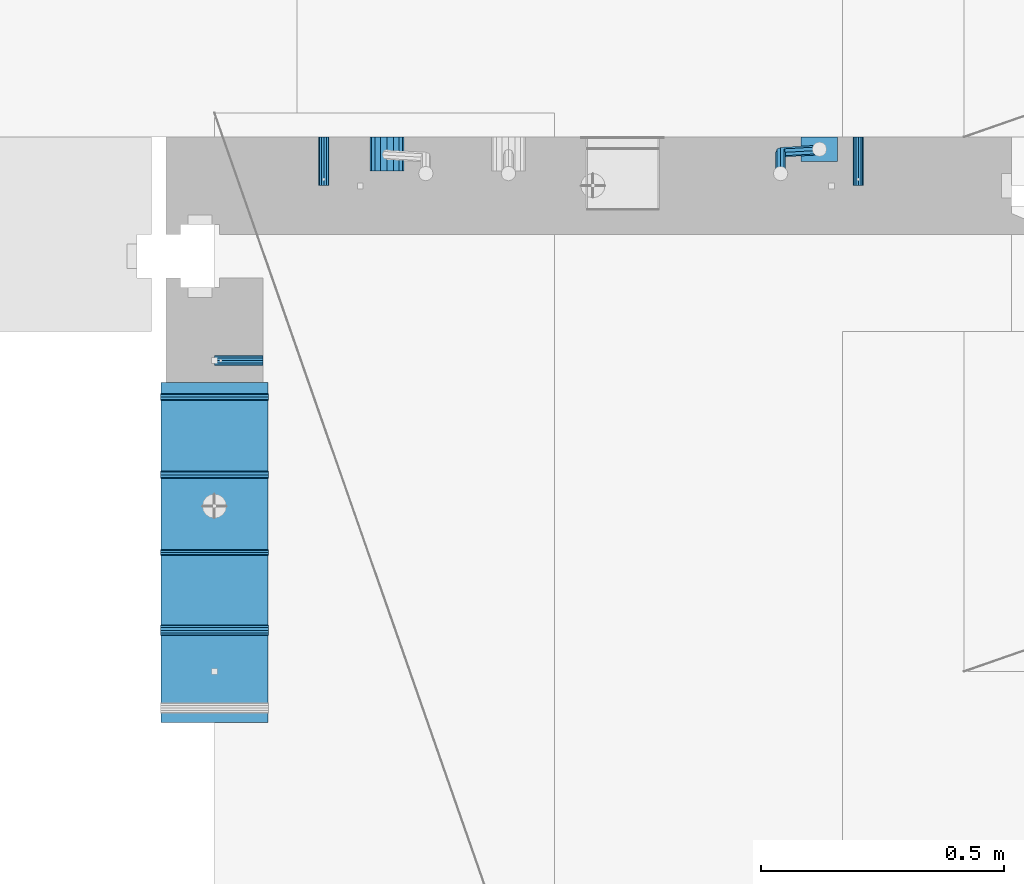
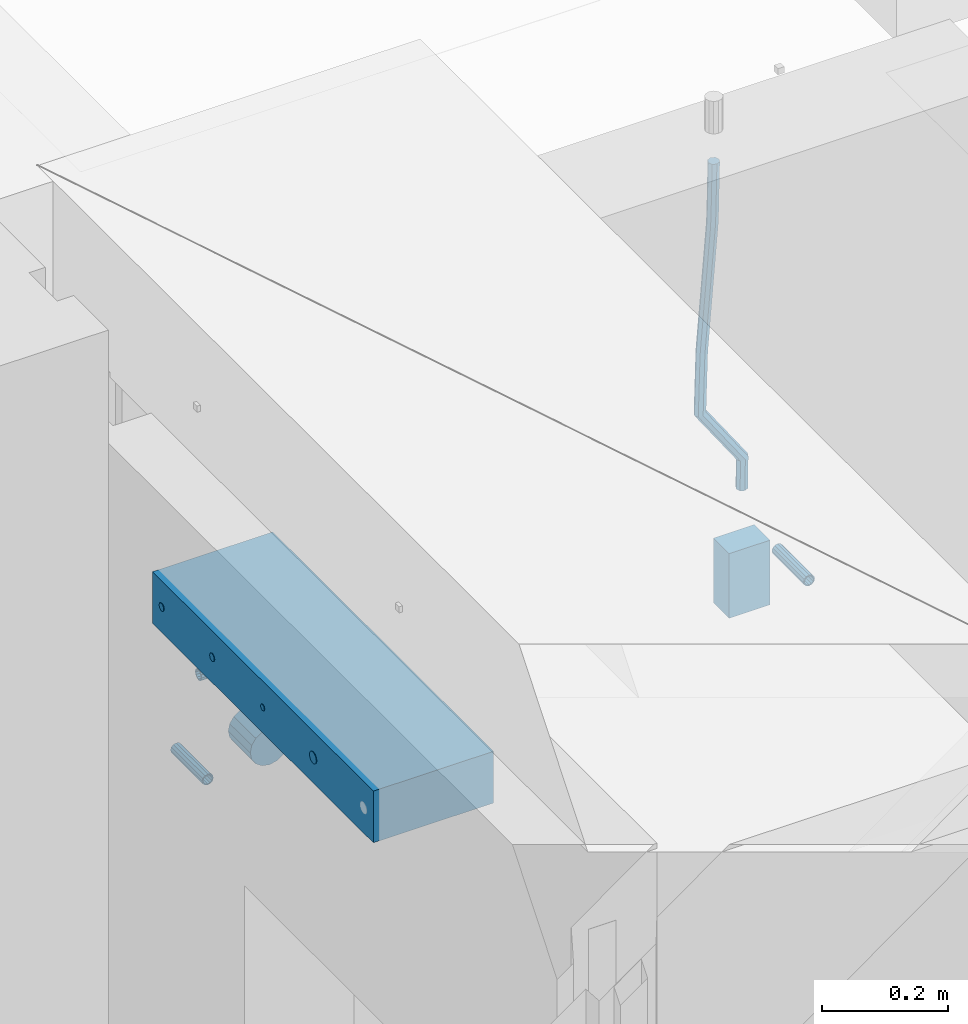
# One storey, part 159 of 341: 11 beams, 5 elements without a shape of their own.
"""IFC2X3 building model written with IfcOpenShell, lengths in millimetres."""

from ifc_helpers import new_model, si_unit, frame, origin_with_axes, place, context, subcontext, project, spatial, faceted_brep, material, type_object, element, aggregate, save


model = new_model("IFC2X3")

# Units and contexts
model_context = context("Model", 3, precision=1e-05, world=origin_with_axes())
body_context = subcontext(model_context, "Body", "Model", "MODEL_VIEW")
ifc_project = project(units=[si_unit("LENGTHUNIT", "METRE", prefix="MILLI"), si_unit("AREAUNIT", "SQUARE_METRE"), si_unit("VOLUMEUNIT", "CUBIC_METRE"), si_unit("MASSUNIT", "GRAM", prefix="KILO"), si_unit("TIMEUNIT", "SECOND"), si_unit("PLANEANGLEUNIT", "RADIAN"), si_unit("SOLIDANGLEUNIT", "STERADIAN"), si_unit("THERMODYNAMICTEMPERATUREUNIT", "DEGREE_CELSIUS"), si_unit("LUMINOUSINTENSITYUNIT", "LUMEN")], contexts=[model_context])

# Site, building, storey
site_placement = place(None, origin_with_axes())
site = spatial("IfcSite", under=ifc_project, at=site_placement, CompositionType="ELEMENT")
building_placement = place(site_placement, origin_with_axes())
building = spatial("IfcBuilding", under=site, at=building_placement, CompositionType="ELEMENT")
storey_placement = place(building_placement, origin_with_axes())
storey = spatial("IfcBuildingStorey", under=building, at=storey_placement, Name="5", CompositionType="ELEMENT", Elevation=0.0)

# Assemblies, beam
assembly_1_placement = place(storey_placement, origin_with_axes())
assembly_1 = element("IfcElementAssembly", 1, at=assembly_1_placement, inside=storey, AssemblyPlace="NOTDEFINED", PredefinedType="REINFORCEMENT_UNIT")
assembly_2_placement = place(assembly_1_placement, origin_with_axes())
assembly_2 = element("IfcElementAssembly", 2, at=assembly_2_placement, Name="Steel Assembly", AssemblyPlace="NOTDEFINED", PredefinedType="RIGID_FRAME")
ifc_material_1 = material(Name="STEEL/Steel_Undefined")
beam_type_1 = type_object("IfcBeamType", PredefinedType="NOTDEFINED")
beam_1_placement = place(assembly_2_placement, frame((26709.9991475894, 16620.0032612672, 96055.0), z_axis=(0.0, 1.0, 0.0), x_axis=(-1.0, 3.00000001838171e-08, 0.0)))
beam_1 = element("IfcBeam", 3, at=beam_1_placement, type_object=beam_type_1, material=ifc_material_1, Name="M16", context=body_context, shape_type="Brep", body=[
    faceted_brep([(0.0, -8.49999999999272, -1.45519152283669e-11), (0.0, -7.36121593215648, 4.24999999998545), (100.000000000262, -7.36121593215648, 4.24999999998545), (100.000000000262, -8.49999999999272, -1.45519152283669e-11), (0.0, -4.24999999998545, 7.36121593216376), (100.000000000262, -4.24999999998545, 7.36121593216376), (0.0, 1.45519152283669e-11, 8.49999999998545), (100.000000000262, 1.45519152283669e-11, 8.49999999998545), (0.0, 4.25000000001455, 7.36121593216376), (100.000000000262, 4.25000000001455, 7.36121593216376), (0.0, 7.36121593217104, 4.24999999998545), (100.000000000262, 7.36121593217104, 4.24999999998545), (0.0, 8.50000000000728, 0.0), (100.000000000262, 8.50000000000728, 0.0), (0.0, 7.36121593217104, -4.25000000001455), (100.000000000262, 7.36121593217104, -4.25000000001455), (0.0, 4.25000000000728, -7.36121593219286), (100.000000000262, 4.25000000000728, -7.36121593219286), (0.0, 7.27595761418343e-12, -8.5), (100.000000000262, 7.27595761418343e-12, -8.5), (0.0, -4.24999999999272, -7.36121593217831), (100.000000000262, -4.24999999999272, -7.36121593217831), (0.0, -7.36121593215648, -4.25), (100.000000000262, -7.36121593215648, -4.25), (0.0, -10.4999999999927, -1.45519152283669e-11), (0.0, -9.09326673972828, -5.25000000001455), (100.000000000262, -9.09326673972828, -5.25000000001455), (100.000000000262, -10.4999999999927, -1.45519152283669e-11), (0.0, -5.24999999998545, -9.09326673974283), (100.000000000262, -5.24999999998545, -9.09326673974283), (0.0, 7.27595761418343e-12, -10.5), (100.000000000262, 7.27595761418343e-12, -10.5), (0.0, 5.25000000001455, -9.09326673975738), (100.000000000262, 5.25000000001455, -9.09326673975738), (0.0, 9.09326673975011, -5.25000000001455), (100.000000000262, 9.09326673975011, -5.25000000001455), (0.0, 10.5000000000073, -1.45519152283669e-11), (100.000000000262, 10.5000000000073, -1.45519152283669e-11), (0.0, 9.09326673975011, 5.25), (100.000000000262, 9.09326673975011, 5.25), (0.0, 5.25000000000728, 9.09326673972828), (100.000000000262, 5.25000000000728, 9.09326673972828), (0.0, 1.45519152283669e-11, 10.4999999999854), (100.000000000262, 1.45519152283669e-11, 10.4999999999854), (0.0, -5.24999999999272, 9.09326673972828), (100.000000000262, -5.24999999999272, 9.09326673972828), (0.0, -9.09326673972828, 5.24999999998545), (100.000000000262, -9.09326673972828, 5.24999999998545)], [[[0, 1, 2, 3]], [[1, 4, 5, 2]], [[4, 6, 7, 5]], [[6, 8, 9, 7]], [[8, 10, 11, 9]], [[10, 12, 13, 11]], [[12, 14, 15, 13]], [[14, 16, 17, 15]], [[16, 18, 19, 17]], [[18, 20, 21, 19]], [[20, 22, 23, 21]], [[22, 0, 3, 23]], [[24, 25, 26, 27]], [[25, 28, 29, 26]], [[28, 30, 31, 29]], [[30, 32, 33, 31]], [[32, 34, 35, 33]], [[34, 36, 37, 35]], [[36, 38, 39, 37]], [[38, 40, 41, 39]], [[40, 42, 43, 41]], [[42, 44, 45, 43]], [[44, 46, 47, 45]], [[46, 24, 27, 47]], [[29, 31, 33, 35, 37, 39, 41, 43, 45, 47, 27, 26], [5, 7, 9, 11, 13, 15, 17, 19, 21, 23, 3, 2]], [[46, 44, 42, 40, 38, 36, 34, 32, 30, 28, 25, 24], [22, 20, 18, 16, 14, 12, 10, 8, 6, 4, 1, 0]]]),
])
aggregate(assembly_2, [beam_1])

# Assemblies, beams
assembly_3_placement = place(storey_placement, origin_with_axes())
assembly_3 = element("IfcElementAssembly", 4, at=assembly_3_placement, inside=storey, AssemblyPlace="NOTDEFINED", PredefinedType="REINFORCEMENT_UNIT")
assembly_4_placement = place(assembly_3_placement, origin_with_axes())
assembly_4 = element("IfcElementAssembly", 5, at=assembly_4_placement, Name="Steel Assembly", AssemblyPlace="NOTDEFINED", PredefinedType="RIGID_FRAME")
beam_2_placement = place(assembly_4_placement, frame((27934.9999668009, 17080.0, 95555.0), z_axis=(1.0, 0.0, 0.0), x_axis=(0.0, -1.0, 0.0)))
beam_2 = element("IfcBeam", 6, at=beam_2_placement, type_object=beam_type_1, material=ifc_material_1, Name="M16", context=body_context, shape_type="Brep", body=[
    faceted_brep([(0.0, -8.49999999999272, -1.45519152283669e-11), (0.0, -7.36121593215648, 4.24999999998545), (100.000000000262, -7.36121593215648, 4.24999999998545), (100.000000000262, -8.49999999999272, -1.45519152283669e-11), (0.0, -4.24999999998545, 7.36121593216376), (100.000000000262, -4.24999999998545, 7.36121593216376), (0.0, 1.45519152283669e-11, 8.49999999998545), (100.000000000262, 1.45519152283669e-11, 8.49999999998545), (0.0, 4.25000000001455, 7.36121593216376), (100.000000000262, 4.25000000001455, 7.36121593216376), (0.0, 7.36121593217104, 4.24999999998545), (100.000000000262, 7.36121593217104, 4.24999999998545), (0.0, 8.50000000000728, 0.0), (100.000000000262, 8.50000000000728, 0.0), (0.0, 7.36121593217104, -4.25000000001455), (100.000000000262, 7.36121593217104, -4.25000000001455), (0.0, 4.25000000000728, -7.36121593219286), (100.000000000262, 4.25000000000728, -7.36121593219286), (0.0, 7.27595761418343e-12, -8.5), (100.000000000262, 7.27595761418343e-12, -8.5), (0.0, -4.24999999999272, -7.36121593217831), (100.000000000262, -4.24999999999272, -7.36121593217831), (0.0, -7.36121593215648, -4.25), (100.000000000262, -7.36121593215648, -4.25), (0.0, -10.4999999999927, -1.45519152283669e-11), (0.0, -9.09326673972828, -5.25000000001455), (100.000000000262, -9.09326673972828, -5.25000000001455), (100.000000000262, -10.4999999999927, -1.45519152283669e-11), (0.0, -5.24999999998545, -9.09326673974283), (100.000000000262, -5.24999999998545, -9.09326673974283), (0.0, 7.27595761418343e-12, -10.5), (100.000000000262, 7.27595761418343e-12, -10.5), (0.0, 5.25000000001455, -9.09326673975738), (100.000000000262, 5.25000000001455, -9.09326673975738), (0.0, 9.09326673975011, -5.25000000001455), (100.000000000262, 9.09326673975011, -5.25000000001455), (0.0, 10.5000000000073, -1.45519152283669e-11), (100.000000000262, 10.5000000000073, -1.45519152283669e-11), (0.0, 9.09326673975011, 5.25), (100.000000000262, 9.09326673975011, 5.25), (0.0, 5.25000000000728, 9.09326673972828), (100.000000000262, 5.25000000000728, 9.09326673972828), (0.0, 1.45519152283669e-11, 10.4999999999854), (100.000000000262, 1.45519152283669e-11, 10.4999999999854), (0.0, -5.24999999999272, 9.09326673972828), (100.000000000262, -5.24999999999272, 9.09326673972828), (0.0, -9.09326673972828, 5.24999999998545), (100.000000000262, -9.09326673972828, 5.24999999998545)], [[[0, 1, 2, 3]], [[1, 4, 5, 2]], [[4, 6, 7, 5]], [[6, 8, 9, 7]], [[8, 10, 11, 9]], [[10, 12, 13, 11]], [[12, 14, 15, 13]], [[14, 16, 17, 15]], [[16, 18, 19, 17]], [[18, 20, 21, 19]], [[20, 22, 23, 21]], [[22, 0, 3, 23]], [[24, 25, 26, 27]], [[25, 28, 29, 26]], [[28, 30, 31, 29]], [[30, 32, 33, 31]], [[32, 34, 35, 33]], [[34, 36, 37, 35]], [[36, 38, 39, 37]], [[38, 40, 41, 39]], [[40, 42, 43, 41]], [[42, 44, 45, 43]], [[44, 46, 47, 45]], [[46, 24, 27, 47]], [[29, 31, 33, 35, 37, 39, 41, 43, 45, 47, 27, 26], [5, 7, 9, 11, 13, 15, 17, 19, 21, 23, 3, 2]], [[46, 44, 42, 40, 38, 36, 34, 32, 30, 28, 25, 24], [22, 20, 18, 16, 14, 12, 10, 8, 6, 4, 1, 0]]]),
])
aggregate(assembly_4, [beam_2])
assembly_5_placement = place(assembly_3_placement, origin_with_axes())
assembly_5 = element("IfcElementAssembly", 7, at=assembly_5_placement, Name="Steel Assembly", AssemblyPlace="NOTDEFINED", PredefinedType="RIGID_FRAME")
beam_3_placement = place(assembly_5_placement, frame((26834.9999668009, 17080.0, 95555.0), z_axis=(-1.0, 3.00000001838171e-08, 0.0), x_axis=(0.0, -1.0, 0.0)))
beam_3 = element("IfcBeam", 8, at=beam_3_placement, type_object=beam_type_1, material=ifc_material_1, Name="M16", context=body_context, shape_type="Brep", body=[
    faceted_brep([(0.0, -8.49999999999272, -1.45519152283669e-11), (0.0, -7.36121593215648, 4.24999999998545), (100.000000000262, -7.36121593215648, 4.24999999998545), (100.000000000262, -8.49999999999272, -1.45519152283669e-11), (0.0, -4.24999999998545, 7.36121593216376), (100.000000000262, -4.24999999998545, 7.36121593216376), (0.0, 1.45519152283669e-11, 8.49999999998545), (100.000000000262, 1.45519152283669e-11, 8.49999999998545), (0.0, 4.25000000001455, 7.36121593216376), (100.000000000262, 4.25000000001455, 7.36121593216376), (0.0, 7.36121593217104, 4.24999999998545), (100.000000000262, 7.36121593217104, 4.24999999998545), (0.0, 8.50000000000728, 0.0), (100.000000000262, 8.50000000000728, 0.0), (0.0, 7.36121593217104, -4.25000000001455), (100.000000000262, 7.36121593217104, -4.25000000001455), (0.0, 4.25000000000728, -7.36121593219286), (100.000000000262, 4.25000000000728, -7.36121593219286), (0.0, 7.27595761418343e-12, -8.5), (100.000000000262, 7.27595761418343e-12, -8.5), (0.0, -4.24999999999272, -7.36121593217831), (100.000000000262, -4.24999999999272, -7.36121593217831), (0.0, -7.36121593215648, -4.25), (100.000000000262, -7.36121593215648, -4.25), (0.0, -10.4999999999927, -1.45519152283669e-11), (0.0, -9.09326673972828, -5.25000000001455), (100.000000000262, -9.09326673972828, -5.25000000001455), (100.000000000262, -10.4999999999927, -1.45519152283669e-11), (0.0, -5.24999999998545, -9.09326673974283), (100.000000000262, -5.24999999998545, -9.09326673974283), (0.0, 7.27595761418343e-12, -10.5), (100.000000000262, 7.27595761418343e-12, -10.5), (0.0, 5.25000000001455, -9.09326673975738), (100.000000000262, 5.25000000001455, -9.09326673975738), (0.0, 9.09326673975011, -5.25000000001455), (100.000000000262, 9.09326673975011, -5.25000000001455), (0.0, 10.5000000000073, -1.45519152283669e-11), (100.000000000262, 10.5000000000073, -1.45519152283669e-11), (0.0, 9.09326673975011, 5.25), (100.000000000262, 9.09326673975011, 5.25), (0.0, 5.25000000000728, 9.09326673972828), (100.000000000262, 5.25000000000728, 9.09326673972828), (0.0, 1.45519152283669e-11, 10.4999999999854), (100.000000000262, 1.45519152283669e-11, 10.4999999999854), (0.0, -5.24999999999272, 9.09326673972828), (100.000000000262, -5.24999999999272, 9.09326673972828), (0.0, -9.09326673972828, 5.24999999998545), (100.000000000262, -9.09326673972828, 5.24999999998545)], [[[0, 1, 2, 3]], [[1, 4, 5, 2]], [[4, 6, 7, 5]], [[6, 8, 9, 7]], [[8, 10, 11, 9]], [[10, 12, 13, 11]], [[12, 14, 15, 13]], [[14, 16, 17, 15]], [[16, 18, 19, 17]], [[18, 20, 21, 19]], [[20, 22, 23, 21]], [[22, 0, 3, 23]], [[24, 25, 26, 27]], [[25, 28, 29, 26]], [[28, 30, 31, 29]], [[30, 32, 33, 31]], [[32, 34, 35, 33]], [[34, 36, 37, 35]], [[36, 38, 39, 37]], [[38, 40, 41, 39]], [[40, 42, 43, 41]], [[42, 44, 45, 43]], [[44, 46, 47, 45]], [[46, 24, 27, 47]], [[29, 31, 33, 35, 37, 39, 41, 43, 45, 47, 27, 26], [5, 7, 9, 11, 13, 15, 17, 19, 21, 23, 3, 2]], [[46, 44, 42, 40, 38, 36, 34, 32, 30, 28, 25, 24], [22, 20, 18, 16, 14, 12, 10, 8, 6, 4, 1, 0]]]),
])
aggregate(assembly_5, [beam_3])
ifc_material_2 = material()
beam_type_2 = type_object("IfcBeamType", Name="D20", PredefinedType="NOTDEFINED")
beam_4_placement = place(assembly_3_placement, frame((27854.9999105249, 17055.0000022791, 95717.5), z_axis=(0.00020576299992186, -0.999642804629538, -0.0267249099901004), x_axis=(-4.30000201928125e-08, -0.0267249099948059, 0.999642825806181)))
beam_4 = element("IfcBeam", 9, at=beam_4_placement, type_object=beam_type_2, material=ifc_material_2, Name="JM20", ObjectType="D20", context=body_context, shape_type="Brep", body=[
    faceted_brep([(0.0, -10.0, 0.0), (-4.19531716033816e-08, -7.07106781186667, -7.07106781187031), (57.3778003524785, -7.07106779628884, -7.0710678060168), (57.3778003565822, -9.99999998442945, 5.84986992180347e-09), (0.0, 0.0, -10.0), (57.3778003491898, 1.55741872731596e-08, -9.99999999415013), (4.196772351861e-08, 7.07106781186303, -7.07106781186667), (57.3778003486368, 7.07106782744086, -7.0710678060168), (0.0, 10.0, 0.0), (57.3778003511543, 10.0000000155705, 5.84986992180347e-09), (4.196772351861e-08, 7.07106781185939, 7.07106781185939), (57.3778003552725, 7.07106782744086, 7.0710678177129), (0.0, 0.0, 10.0), (57.3778003585467, 1.55741872731596e-08, 10.0000000058535), (-4.19531716033816e-08, -7.07106781187031, 7.07106781185939), (57.3778003591142, -7.07106779628884, 7.0710678177129), (63.2348501311644, -7.07106779493188, -7.07106780540926), (64.1057957623998, -9.99999998283238, 6.54472387395799e-09), (61.04994790192, 1.63490767590702e-08, -9.99999999377178), (58.8309751681372, 7.07106782761548, -7.07106780586037), (57.8777760627127, 10.0000000155014, 5.90807758271694e-09), (58.7487216939626, 7.07106782759729, 7.07106781786206), (60.9336239231925, 1.63163349498063e-08, 10.0000000062173), (63.1525966569752, -7.07106779495371, 7.07106781830953), (68.0560815638019, -3.74583294561307, -7.00896065082998), (69.6439432500047, -6.18030344188082, 0.0713424813729944), (64.0726841869619, 2.08480100043016, -9.96106107280502), (60.0271712784888, 7.89609210789058, -7.05565839484916), (58.2893494334276, 10.283864860914, 0.00530189843993867), (59.8772111196158, 7.84939436464629, 7.08560503063927), (63.8606084964704, 2.01876041860305, 10.037705452618), (67.9061214049289, -3.79253068885737, 7.13230277466573), (178.098456601496, 72.1511127806843, -5.59139360533663), (179.686318287684, 69.716642284413, 1.48890952685906), (174.115059224641, 77.9817467267239, -8.54349402731532), (170.069546316168, 83.7930378341844, -5.63809134935946), (168.331724471092, 86.1808105872078, 1.42286894392964), (169.91958615731, 83.7463400909437, 8.50317207612898), (173.90298353415, 77.9157061448968, 11.455272498104), (177.948496442623, 72.1044150374437, 8.5498698201518), (179.289255982527, 72.9724149014583, -5.57605371504542), (180.097891658399, 70.0005071298292, 1.4942114193982), (177.129995245661, 80.0611678177193, -8.50465558942597), (174.884975102759, 87.1142705605816, -5.5760589445199), (173.869297905752, 90.00011120009, 1.49420402380565), (174.67793358161, 87.0282034284573, 8.5644691582529), (176.837194318476, 79.9394505121963, 11.4930710326298), (179.082214461378, 72.8863477693376, 8.56447438772739), (180.735622590379, 72.972420835973, -5.54778204405011), (180.597796167538, 70.0005091809617, 1.50398289485383), (180.791991426609, 80.0611828430738, -8.4330757073476), (180.733882576489, 87.1142945589418, -5.46173219850607), (180.595335416292, 90.0001387973534, 1.62567575346111), (180.457508993451, 87.0282271423457, 8.67744069236505), (180.401140157206, 79.939465135245, 11.5627343556625), (180.459249007356, 72.8863534193733, 8.59139084682101), (299.223827734662, 72.9729069989553, -3.23173054285144), (299.086001311836, 70.0009953439476, 3.82003439605251), (299.280196570893, 80.0616690060597, -6.11702420615256), (299.222087720773, 87.1147807219277, -3.14568069731467), (299.083540560576, 90.0006249603393, 3.94172725465251), (298.945714137735, 87.0287133053316, 10.9934921935564), (298.889345301504, 79.9399512982272, 13.8787858568576), (298.947454151639, 72.8868395823556, 10.9074423480197), (300.386274806908, 72.9729117685347, -3.20900855728542), (299.975441269635, 70.0009989933678, 3.8374199978316), (300.554299891708, 80.0616742337661, -6.09211971118202), (300.381089708186, 87.1147854773699, -3.12302605173682), (299.968108432717, 90.0006285897653, 3.95901762330686), (299.557274895458, 87.0287158145948, 11.0054461784239), (299.389249810658, 79.9399533493597, 13.8885573323169), (299.562459994166, 72.8868421057559, 10.9194636728716), (301.54348499664, 72.972935138263, -3.09647384826167), (300.860874255726, 70.0010168745794, 3.92352530897551), (301.822663312996, 80.0616998482183, -5.96877573286474), (301.534870333402, 87.1148087778347, -3.01082485606094), (300.848691282124, 90.0006463730351, 4.04465127535514), (300.166080541225, 87.0287281093551, 11.0646504325923), (299.886902224855, 79.9399633993926, 13.9369523171918), (300.174695204449, 72.8868544697798, 10.9790014403879), (567.277632096637, 72.9783016087349, 22.7452575737989), (566.595021355723, 70.0063833450513, 29.7652567310361), (567.556810412992, 80.0670663186975, 19.8729556891958), (567.269017433413, 87.1201752483139, 22.8309065659996), (566.582838382135, 90.0060128435071, 29.886382697412), (565.900227641221, 87.0340945798234, 36.9063818546456), (565.621049324851, 79.9453298698681, 39.7786837392523), (565.90884230446, 72.8922209402554, 36.8207328624449), (567.849310941645, 72.9783131537188, 22.8008513743443), (567.441064932689, 70.0064004308078, 29.8475315576834), (568.054462827218, 80.0670763687303, 19.9213506740707), (567.93634539716, 87.1201887249226, 22.8958019142228), (567.564150240039, 90.0060326609891, 29.9818118989315), (567.155904231084, 87.0341199380709, 37.0284920822669), (566.950752345525, 79.9453567230667, 39.9079927825405), (567.068869775569, 72.8922443668707, 36.9335415423957), (568.423586898687, 72.9708243880268, 22.8084944200891), (568.290952048657, 69.9953175961527, 29.8588427157192), (568.554376054599, 80.0605573198627, 19.9280040253361), (568.606705002705, 87.1114469937784, 22.9047237384184), (568.549920154881, 89.9931778656028, 29.9949315228005), (568.417285304851, 87.0176710737251, 37.0452798184269), (568.286496148939, 79.9279381418964, 39.9257702131799), (568.234167200833, 72.8770484679771, 36.9490505000977), (589.912124239258, 72.6906061074042, 23.0944856267633), (589.779489389242, 69.7150993155265, 30.1448339223862), (590.042913395198, 79.7803390392328, 20.2139952320067), (590.095242343275, 86.8312287131521, 23.190714945089), (590.038457495451, 89.7129595849765, 30.2809227294711), (589.905822645451, 86.7374527930988, 37.3312710250975), (589.775033489525, 79.6477198612702, 40.2117614198505), (589.722704541418, 72.5968301873472, 37.2350417067682), (590.547165551296, 72.6823249395493, 23.1029373993588), (590.439554471668, 69.7064918286778, 30.1536187366546), (590.620682129796, 79.7728047264573, 20.2216847631717), (590.617039192599, 86.8244242939545, 23.197659545749), (590.538370722847, 89.7064405361089, 30.2875760807365), (590.430759643248, 86.7306074252338, 37.3382574180287), (590.357243064718, 79.6401276383258, 40.2195100542194), (590.36088600193, 72.5885080708285, 37.243535271642), (591.182260594243, 72.6841934809891, 23.1112002334121), (591.099675200006, 69.7084600799535, 30.1622167658497), (591.198500084778, 79.7744922147613, 20.2291794306657), (591.138880798317, 86.8259554442993, 23.2044030568104), (591.038326904265, 89.7079316443269, 30.2940254627501), (590.955741510043, 86.7321982432914, 37.3450419951805), (590.939502019522, 79.6418995095191, 40.2270627979342), (590.999121305984, 72.5904362799774, 37.2518391717822), (691.203058405095, 72.9824563748625, 24.4085746238379), (691.120473010888, 70.0067229738306, 31.4595911562756), (691.219297895645, 80.0727551086347, 21.5265538210951), (691.159678609169, 87.1242183381728, 24.5017774472362), (691.059124715146, 90.0061945381967, 31.591399853176), (690.976539320895, 87.0304611371721, 38.6424163856136), (690.960299830374, 79.9401624033926, 41.5244371883564), (691.019919116836, 72.8886991738545, 38.5492135622153)], [[[0, 1, 2, 3]], [[1, 4, 5, 2]], [[4, 6, 7, 5]], [[6, 8, 9, 7]], [[8, 10, 11, 9]], [[10, 12, 13, 11]], [[12, 14, 15, 13]], [[14, 0, 3, 15]], [[14, 12, 10, 8, 6, 4, 1, 0]], [[3, 2, 16, 17]], [[2, 5, 18, 16]], [[5, 7, 19, 18]], [[7, 9, 20, 19]], [[9, 11, 21, 20]], [[11, 13, 22, 21]], [[13, 15, 23, 22]], [[15, 3, 17, 23]], [[17, 16, 24, 25]], [[16, 18, 26, 24]], [[18, 19, 27, 26]], [[19, 20, 28, 27]], [[20, 21, 29, 28]], [[21, 22, 30, 29]], [[22, 23, 31, 30]], [[23, 17, 25, 31]], [[25, 24, 32, 33]], [[24, 26, 34, 32]], [[26, 27, 35, 34]], [[27, 28, 36, 35]], [[28, 29, 37, 36]], [[29, 30, 38, 37]], [[30, 31, 39, 38]], [[31, 25, 33, 39]], [[33, 32, 40, 41]], [[32, 34, 42, 40]], [[34, 35, 43, 42]], [[35, 36, 44, 43]], [[36, 37, 45, 44]], [[37, 38, 46, 45]], [[38, 39, 47, 46]], [[39, 33, 41, 47]], [[41, 40, 48, 49]], [[40, 42, 50, 48]], [[42, 43, 51, 50]], [[43, 44, 52, 51]], [[44, 45, 53, 52]], [[45, 46, 54, 53]], [[46, 47, 55, 54]], [[47, 41, 49, 55]], [[49, 48, 56, 57]], [[48, 50, 58, 56]], [[50, 51, 59, 58]], [[51, 52, 60, 59]], [[52, 53, 61, 60]], [[53, 54, 62, 61]], [[54, 55, 63, 62]], [[55, 49, 57, 63]], [[57, 56, 64, 65]], [[56, 58, 66, 64]], [[58, 59, 67, 66]], [[59, 60, 68, 67]], [[60, 61, 69, 68]], [[61, 62, 70, 69]], [[62, 63, 71, 70]], [[63, 57, 65, 71]], [[65, 64, 72, 73]], [[64, 66, 74, 72]], [[66, 67, 75, 74]], [[67, 68, 76, 75]], [[68, 69, 77, 76]], [[69, 70, 78, 77]], [[70, 71, 79, 78]], [[71, 65, 73, 79]], [[73, 72, 80, 81]], [[72, 74, 82, 80]], [[74, 75, 83, 82]], [[75, 76, 84, 83]], [[76, 77, 85, 84]], [[77, 78, 86, 85]], [[78, 79, 87, 86]], [[79, 73, 81, 87]], [[81, 80, 88, 89]], [[80, 82, 90, 88]], [[82, 83, 91, 90]], [[83, 84, 92, 91]], [[84, 85, 93, 92]], [[85, 86, 94, 93]], [[86, 87, 95, 94]], [[87, 81, 89, 95]], [[89, 88, 96, 97]], [[88, 90, 98, 96]], [[90, 91, 99, 98]], [[91, 92, 100, 99]], [[92, 93, 101, 100]], [[93, 94, 102, 101]], [[94, 95, 103, 102]], [[95, 89, 97, 103]], [[97, 96, 104, 105]], [[96, 98, 106, 104]], [[98, 99, 107, 106]], [[99, 100, 108, 107]], [[100, 101, 109, 108]], [[101, 102, 110, 109]], [[102, 103, 111, 110]], [[103, 97, 105, 111]], [[105, 104, 112, 113]], [[104, 106, 114, 112]], [[106, 107, 115, 114]], [[107, 108, 116, 115]], [[108, 109, 117, 116]], [[109, 110, 118, 117]], [[110, 111, 119, 118]], [[111, 105, 113, 119]], [[113, 112, 120, 121]], [[112, 114, 122, 120]], [[114, 115, 123, 122]], [[115, 116, 124, 123]], [[116, 117, 125, 124]], [[117, 118, 126, 125]], [[118, 119, 127, 126]], [[119, 113, 121, 127]], [[121, 120, 128, 129]], [[120, 122, 130, 128]], [[122, 123, 131, 130]], [[123, 124, 132, 131]], [[124, 125, 133, 132]], [[125, 126, 134, 133]], [[126, 127, 135, 134]], [[127, 121, 129, 135]], [[130, 131, 132, 133, 134, 135, 129, 128]]]),
])
beam_type_3 = type_object("IfcBeamType", Name="D70", PredefinedType="NOTDEFINED")
beam_5_placement = place(assembly_3_placement, frame((26964.9999105288, 17080.0000022791, 95555.0), z_axis=(0.0, 0.0, 1.0), x_axis=(0.0, -1.0, 0.0)))
beam_5 = element("IfcBeam", 10, at=beam_5_placement, type_object=beam_type_3, material=ifc_material_2, ObjectType="D70", context=body_context, shape_type="Brep", body=[
    faceted_brep([(0.0, -35.0, 0.0), (0.0, -32.3357836378964, -13.3939201327739), (70.0, -32.3357836378964, -13.3939201327739), (70.0, -35.0, 0.0), (0.0, -24.7487373415279, -24.7487373415352), (70.0, -24.7487373415279, -24.7487373415352), (0.0, -13.3939201327776, -32.3357836379), (70.0, -13.3939201327776, -32.3357836379), (0.0, 0.0, -35.0), (70.0, 0.0, -35.0), (0.0, 13.3939201327776, -32.3357836379), (70.0, 13.3939201327776, -32.3357836379), (0.0, 24.7487373415279, -24.7487373415352), (70.0, 24.7487373415279, -24.7487373415352), (0.0, 32.3357836378964, -13.3939201327739), (70.0, 32.3357836378964, -13.3939201327739), (0.0, 35.0, 0.0), (70.0, 35.0, 0.0), (0.0, 32.3357836378964, 13.3939201327739), (70.0, 32.3357836378964, 13.3939201327739), (0.0, 24.7487373415279, 24.7487373415352), (70.0, 24.7487373415279, 24.7487373415352), (0.0, 13.3939201327776, 32.3357836379), (70.0, 13.3939201327776, 32.3357836379), (0.0, 0.0, 35.0), (70.0, 0.0, 35.0), (0.0, -13.3939201327776, 32.3357836379), (70.0, -13.3939201327776, 32.3357836379), (0.0, -24.7487373415279, 24.7487373415352), (70.0, -24.7487373415279, 24.7487373415352), (0.0, -32.3357836378964, 13.3939201327739), (70.0, -32.3357836378964, 13.3939201327739)], [[[0, 1, 2, 3]], [[1, 4, 5, 2]], [[4, 6, 7, 5]], [[6, 8, 9, 7]], [[8, 10, 11, 9]], [[10, 12, 13, 11]], [[12, 14, 15, 13]], [[14, 16, 17, 15]], [[16, 18, 19, 17]], [[18, 20, 21, 19]], [[20, 22, 23, 21]], [[22, 24, 25, 23]], [[24, 26, 27, 25]], [[26, 28, 29, 27]], [[28, 30, 31, 29]], [[30, 0, 3, 31]], [[5, 7, 9, 11, 13, 15, 17, 19, 21, 23, 25, 27, 29, 31, 3, 2]], [[30, 28, 26, 24, 22, 20, 18, 16, 14, 12, 10, 8, 6, 4, 1, 0]]]),
])

# Beam
ifc_material_3 = material()
beam_type_4 = type_object("IfcBeamType", Name="D12", PredefinedType="NOTDEFINED")
beam_6_placement = place(assembly_1_placement, frame((26720.9994161083, 16225.0, 96270.0), z_axis=(0.0, -1.0, 0.0), x_axis=(-1.0, 3.00000001838171e-08, 0.0)))
beam_6 = element("IfcBeam", 11, at=beam_6_placement, type_object=beam_type_4, material=ifc_material_3, Name="12", ObjectType="D12", context=body_context, shape_type="Brep", body=[
    faceted_brep([(0.0, -6.0, -1.45519152283669e-11), (0.0, -4.24264068712, -4.24264068713819), (222.000077784061, -4.24264068712364, -4.24264068712), (222.000077784061, -6.0, 0.0), (3.63797880709171e-12, 0.0, -6.0000000000291), (222.000077784061, 0.0, -6.0), (0.0, 4.24264068712, -4.24264068713819), (222.000077784061, 4.24264068712364, -4.24264068712), (0.0, 6.0, -1.45519152283669e-11), (222.000077784061, 6.0, 0.0), (0.0, 4.24264068712, 4.24264068709454), (222.000077784061, 4.24264068712364, 4.24264068712), (0.0, 0.0, 5.99999999998545), (222.000077784061, 0.0, 6.0), (0.0, -4.24264068712, 4.24264068709454), (222.000077784061, -4.24264068712364, 4.24264068712)], [[[0, 1, 2, 3]], [[1, 4, 5, 2]], [[4, 6, 7, 5]], [[6, 8, 9, 7]], [[8, 10, 11, 9]], [[10, 12, 13, 11]], [[12, 14, 15, 13]], [[14, 0, 3, 15]], [[5, 7, 9, 11, 13, 15, 3, 2]], [[14, 12, 10, 8, 6, 4, 1, 0]]]),
])

beam_type_5 = type_object("IfcBeamType", Name="D15", PredefinedType="NOTDEFINED")
beam_7_placement = place(assembly_1_placement, frame((26720.9994161083, 16544.9998474121, 96270.0), z_axis=(0.0, -1.0, 0.0), x_axis=(-1.0, 3.00000001838171e-08, 0.0)))
beam_7 = element("IfcBeam", 12, at=beam_7_placement, type_object=beam_type_5, material=ifc_material_3, Name="15", ObjectType="D15", context=body_context, shape_type="Brep", body=[
    faceted_brep([(0.0, -7.5, 0.0), (0.0, -5.30330085889727, -5.30330085890091), (222.000077784061, -5.30330085889727, -5.30330085890091), (222.000077784061, -7.5, 0.0), (0.0, 1.45519152283669e-11, -7.5), (222.000077784061, 0.0, -7.5), (0.0, 5.30330085889727, -5.30330085890091), (222.000077784061, 5.30330085889727, -5.30330085890091), (0.0, 7.5, 0.0), (222.000077784061, 7.5, 0.0), (0.0, 5.30330085889727, 5.30330085890091), (222.000077784061, 5.30330085889727, 5.30330085890091), (0.0, 1.45519152283669e-11, 7.5), (222.000077784061, 0.0, 7.5), (0.0, -5.30330085889727, 5.30330085890091), (222.000077784061, -5.30330085889727, 5.30330085890091)], [[[0, 1, 2, 3]], [[1, 4, 5, 2]], [[4, 6, 7, 5]], [[6, 8, 9, 7]], [[8, 10, 11, 9]], [[10, 12, 13, 11]], [[12, 14, 15, 13]], [[14, 0, 3, 15]], [[5, 7, 9, 11, 13, 15, 3, 2]], [[14, 12, 10, 8, 6, 4, 1, 0]]]),
])

beam_8_placement = place(assembly_1_placement, frame((26720.9994161083, 16385.0, 96270.0), z_axis=(0.0, -1.0, 0.0), x_axis=(-1.0, 3.00000001838171e-08, 0.0)))
beam_8 = element("IfcBeam", 13, at=beam_8_placement, type_object=beam_type_5, material=ifc_material_3, Name="15", ObjectType="D15", context=body_context, shape_type="Brep", body=[
    faceted_brep([(0.0, -7.5, 0.0), (0.0, -5.30330085889727, -5.30330085890091), (222.000077784061, -5.30330085889727, -5.30330085890091), (222.000077784061, -7.5, 0.0), (0.0, 1.45519152283669e-11, -7.5), (222.000077784061, 0.0, -7.5), (0.0, 5.30330085889727, -5.30330085890091), (222.000077784061, 5.30330085889727, -5.30330085890091), (0.0, 7.5, 0.0), (222.000077784061, 7.5, 0.0), (0.0, 5.30330085889727, 5.30330085890091), (222.000077784061, 5.30330085889727, 5.30330085890091), (0.0, 1.45519152283669e-11, 7.5), (222.000077784061, 0.0, 7.5), (0.0, -5.30330085889727, 5.30330085890091), (222.000077784061, -5.30330085889727, 5.30330085890091)], [[[0, 1, 2, 3]], [[1, 4, 5, 2]], [[4, 6, 7, 5]], [[6, 8, 9, 7]], [[8, 10, 11, 9]], [[10, 12, 13, 11]], [[12, 14, 15, 13]], [[14, 0, 3, 15]], [[5, 7, 9, 11, 13, 15, 3, 2]], [[14, 12, 10, 8, 6, 4, 1, 0]]]),
])

beam_type_6 = type_object("IfcBeamType", Name="D22", PredefinedType="NOTDEFINED")
beam_9_placement = place(assembly_1_placement, frame((26720.9994161083, 16065.0, 96270.0), z_axis=(0.0, -1.0, 0.0), x_axis=(-1.0, 3.00000001838171e-08, 0.0)))
beam_9 = element("IfcBeam", 14, at=beam_9_placement, type_object=beam_type_6, material=ifc_material_3, Name="22", ObjectType="D22", context=body_context, shape_type="Brep", body=[
    faceted_brep([(0.0, -11.0, 0.0), (0.0, -9.52627944163396, -5.5), (222.000077784061, -9.52627944163396, -5.5), (222.000077784061, -11.0, 0.0), (0.0, -5.5, -9.52627944163032), (222.000077784061, -5.5, -9.52627944163032), (0.0, 0.0, -11.0), (222.000077784061, 0.0, -11.0), (0.0, 5.5, -9.52627944163032), (222.000077784061, 5.5, -9.52627944163032), (0.0, 9.52627944163396, -5.5), (222.000077784061, 9.52627944163396, -5.5), (0.0, 11.0, 0.0), (222.000077784061, 11.0, 0.0), (0.0, 9.52627944163396, 5.5), (222.000077784061, 9.52627944163396, 5.5), (0.0, 5.5, 9.52627944163032), (222.000077784061, 5.5, 9.52627944163032), (0.0, 0.0, 11.0), (222.000077784061, 0.0, 11.0), (0.0, -5.5, 9.52627944163032), (222.000077784061, -5.5, 9.52627944163032), (0.0, -9.52627944163396, 5.5), (222.000077784061, -9.52627944163396, 5.5)], [[[0, 1, 2, 3]], [[1, 4, 5, 2]], [[4, 6, 7, 5]], [[6, 8, 9, 7]], [[8, 10, 11, 9]], [[10, 12, 13, 11]], [[12, 14, 15, 13]], [[14, 16, 17, 15]], [[16, 18, 19, 17]], [[18, 20, 21, 19]], [[20, 22, 23, 21]], [[22, 0, 3, 23]], [[5, 7, 9, 11, 13, 15, 17, 19, 21, 23, 3, 2]], [[22, 20, 18, 16, 14, 12, 10, 8, 6, 4, 1, 0]]]),
])

beam_type_7 = type_object("IfcBeamType", PredefinedType="NOTDEFINED")
beam_10_placement = place(assembly_1_placement, frame((26719.9994161083, 16225.0, 96270.0), z_axis=(0.0, -1.0, 0.0), x_axis=(-1.0, 3.00000001838171e-08, 0.0)))
beam_10 = element("IfcBeam", 15, at=beam_10_placement, type_object=beam_type_7, material=ifc_material_3, context=body_context, shape_type="Brep", body=[
    faceted_brep([(0.0, 50.0, -350.0), (0.0, 50.0, 350.0), (220.000077784061, 50.0, 350.0), (220.000077784061, 50.0, -350.0), (0.0, -50.0, 350.0), (220.000077784061, -50.0, 350.0), (0.0, -50.0, -350.0), (220.000077784061, -50.0, -350.0)], [[[0, 1, 2, 3]], [[1, 4, 5, 2]], [[4, 6, 7, 5]], [[6, 0, 3, 7]], [[5, 7, 3, 2]], [[6, 4, 1, 0]]]),
])

aggregate(assembly_1, [assembly_2, beam_9, beam_6, beam_10, beam_7, beam_8])

beam_type_8 = type_object("IfcBeamType", PredefinedType="NOTDEFINED")
beam_11_placement = place(assembly_3_placement, frame((27892.4999105288, 17055.0, 95555.0), z_axis=(0.0, 0.0, 1.0), x_axis=(-1.0, 3.00000001838171e-08, 0.0)))
beam_11 = element("IfcBeam", 16, at=beam_11_placement, type_object=beam_type_8, material=ifc_material_2, Name="WM1", context=body_context, shape_type="Brep", body=[
    faceted_brep([(0.0, 25.0, -62.5), (0.0, 25.0, 62.5), (75.0, 25.0, 62.5), (75.0, 25.0, -62.5), (0.0, -25.0, 62.5), (75.0, -25.0, 62.5), (0.0, -25.0, -62.5), (75.0, -25.0, -62.5)], [[[0, 1, 2, 3]], [[1, 4, 5, 2]], [[4, 6, 7, 5]], [[6, 0, 3, 7]], [[5, 7, 3, 2]], [[0, 6, 4, 1]]]),
])

aggregate(assembly_3, [assembly_4, assembly_5, beam_4, beam_11, beam_5])

save(model, "model.ifc")
